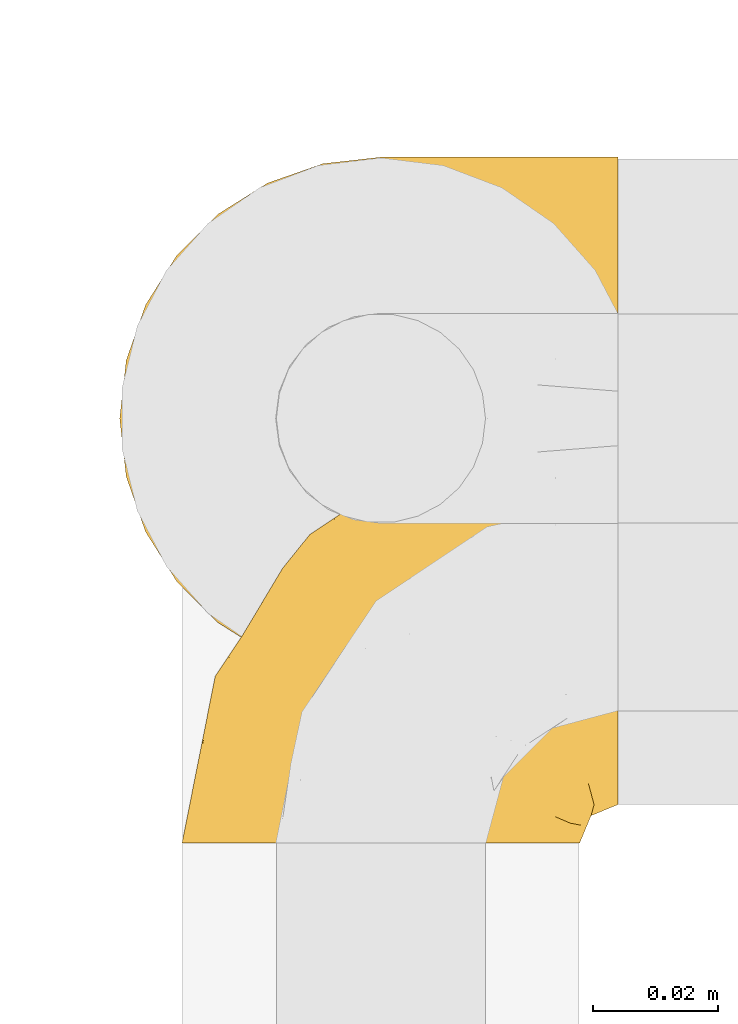
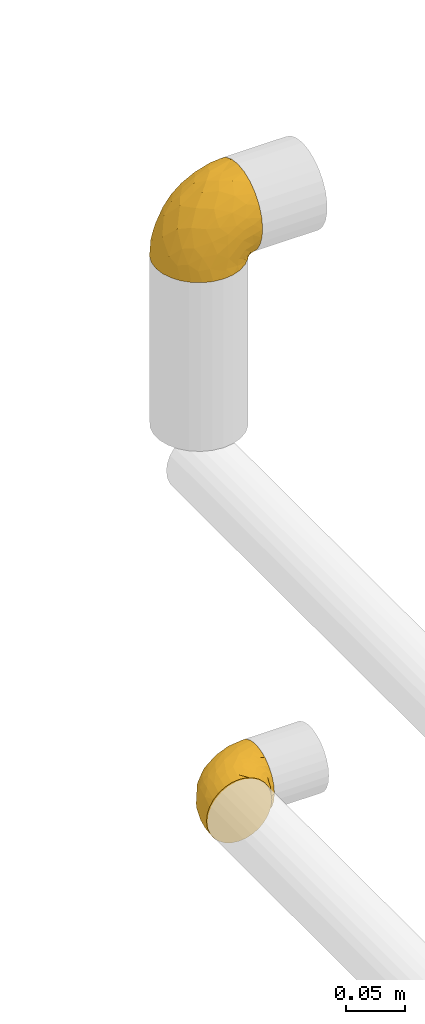
# One storey, part 22 of 39: 2 coverings.
"""IFC2X3 building model written with IfcOpenShell, lengths in millimetres."""

from ifc_helpers import new_model, entity, si_unit, converted_unit, derived_unit, direction, frame, origin, place, context, subcontext, project, spatial, faceted_brep, element, save


model = new_model("IFC2X3")

# Units and contexts
model_context = context("Model", 3, precision=0.01, world=origin(), true_north=direction((6.12303176911189e-17, 1.0)))
body_context = subcontext(model_context, "Body", "Model", "MODEL_VIEW")
ifc_project = project(units=[si_unit("LENGTHUNIT", "METRE", prefix="MILLI"), si_unit("AREAUNIT", "SQUARE_METRE"), si_unit("VOLUMEUNIT", "CUBIC_METRE"), converted_unit("PLANEANGLEUNIT", "DEGREE", entity("IfcRatioMeasure", 0.0174532925199433), si_unit("PLANEANGLEUNIT", "RADIAN"), dimensions=[0, 0, 0, 0, 0, 0, 0]), si_unit("MASSUNIT", "GRAM", prefix="KILO"), derived_unit("MASSDENSITYUNIT", [(si_unit("MASSUNIT", "GRAM", prefix="KILO"), 1), (si_unit("LENGTHUNIT", "METRE"), -3)]), derived_unit("MOMENTOFINERTIAUNIT", [(si_unit("LENGTHUNIT", "METRE"), 4)]), si_unit("TIMEUNIT", "SECOND"), si_unit("FREQUENCYUNIT", "HERTZ"), si_unit("THERMODYNAMICTEMPERATUREUNIT", "DEGREE_CELSIUS"), derived_unit("THERMALTRANSMITTANCEUNIT", [(si_unit("MASSUNIT", "GRAM", prefix="KILO"), 1), (si_unit("THERMODYNAMICTEMPERATUREUNIT", "KELVIN"), -1), (si_unit("TIMEUNIT", "SECOND"), -3)]), derived_unit("VOLUMETRICFLOWRATEUNIT", [(si_unit("LENGTHUNIT", "METRE"), 3), (si_unit("TIMEUNIT", "SECOND"), -1)]), derived_unit("MASSFLOWRATEUNIT", [(si_unit("MASSUNIT", "GRAM", prefix="KILO"), 1), (si_unit("TIMEUNIT", "SECOND"), -1)]), derived_unit("ROTATIONALFREQUENCYUNIT", [(si_unit("TIMEUNIT", "SECOND"), -1)]), si_unit("ELECTRICCURRENTUNIT", "AMPERE"), si_unit("ELECTRICVOLTAGEUNIT", "VOLT"), si_unit("POWERUNIT", "WATT"), si_unit("FORCEUNIT", "NEWTON", prefix="KILO"), si_unit("ILLUMINANCEUNIT", "LUX"), si_unit("LUMINOUSFLUXUNIT", "LUMEN"), si_unit("LUMINOUSINTENSITYUNIT", "CANDELA"), derived_unit("USERDEFINED", [(si_unit("MASSUNIT", "GRAM", prefix="KILO"), -1), (si_unit("LENGTHUNIT", "METRE"), -2), (si_unit("TIMEUNIT", "SECOND"), 3), (si_unit("LUMINOUSFLUXUNIT", "LUMEN"), 1)]), derived_unit("LINEARVELOCITYUNIT", [(si_unit("LENGTHUNIT", "METRE"), 1), (si_unit("TIMEUNIT", "SECOND"), -1)]), si_unit("PRESSUREUNIT", "PASCAL"), derived_unit("USERDEFINED", [(si_unit("LENGTHUNIT", "METRE"), -2), (si_unit("MASSUNIT", "GRAM", prefix="KILO"), 1), (si_unit("TIMEUNIT", "SECOND"), -2)]), derived_unit("LINEARFORCEUNIT", [(si_unit("MASSUNIT", "GRAM", prefix="KILO"), 1), (si_unit("LENGTHUNIT", "METRE"), 1), (si_unit("TIMEUNIT", "SECOND"), -2), (si_unit("LENGTHUNIT", "METRE"), -1)]), derived_unit("PLANARFORCEUNIT", [(si_unit("MASSUNIT", "GRAM", prefix="KILO"), 1), (si_unit("LENGTHUNIT", "METRE"), 1), (si_unit("TIMEUNIT", "SECOND"), -2), (si_unit("LENGTHUNIT", "METRE"), -2)])], contexts=[model_context])

# Site, building, storey
site_placement = place(None, origin())
site = spatial("IfcSite", under=ifc_project, at=site_placement, CompositionType="ELEMENT")
building_placement = place(site_placement, origin())
building = spatial("IfcBuilding", under=site, at=building_placement, CompositionType="ELEMENT")
storey_placement = place(building_placement, frame((0.0, 0.0, 24000.0)))
storey = spatial("IfcBuildingStorey", under=building, at=storey_placement, Name="07", CompositionType="ELEMENT", Elevation=24000.0)

# Coverings
covering_1_placement = place(storey_placement, frame((69571.57, 5253.91, 3610.4)))
element("IfcCovering", 1, at=covering_1_placement, inside=storey, Name=":ADSK_", ObjectType=":ADSK_", PredefinedType="INSULATION", context=body_context, shape_type="Brep", body=[
    faceted_brep([(25.28, 5.74, 1.6), (17.35, 10.73, 1.6), (10.72, 17.36, 1.6), (5.74, 25.29, 1.6), (2.64, 34.14, 1.6), (1.6, 43.45, 1.6), (2.65, 52.76, 1.6), (5.74, 61.61, 1.6), (10.73, 69.54, 1.6), (17.36, 76.17, 1.6), (25.29, 81.15, 1.6), (34.14, 84.25, 1.6), (43.45, 85.3, 1.6), (52.82, 84.23, 1.6), (61.71, 81.1, 1.6), (69.67, 76.06, 1.6), (76.31, 69.36, 1.6), (81.27, 61.36, 1.6), (81.27, 60.44, 1.6), (81.27, 59.52, 1.6), (81.27, 58.72, 1.6), (81.27, 57.4, 1.6), (81.27, 56.08, 1.6), (81.27, 54.76, 1.6), (81.27, 53.44, 1.6), (81.27, 52.12, 1.6), (81.27, 50.8, 1.6), (81.27, 49.47, 1.6), (81.27, 48.15, 1.6), (81.27, 46.83, 1.6), (81.27, 45.51, 1.6), (81.27, 44.19, 1.6), (81.27, 42.87, 1.6), (81.27, 41.55, 1.6), (81.27, 40.23, 1.6), (81.27, 39.31, 1.6), (81.27, 38.39, 1.6), (81.27, 37.48, 1.6), (81.27, 36.56, 1.6), (81.27, 35.64, 1.6), (81.27, 34.72, 1.6), (81.27, 33.8, 1.6), (81.27, 32.88, 1.6), (81.27, 31.96, 1.6), (81.27, 31.05, 1.6), (81.27, 30.13, 1.6), (81.27, 29.21, 1.6), (81.27, 28.29, 1.6), (81.27, 27.37, 1.6), (81.27, 26.45, 1.6), (81.27, 25.53, 1.6), (76.3, 17.52, 1.6), (69.66, 10.82, 1.6), (61.69, 5.78, 1.6), (52.8, 2.65, 1.6), (43.45, 1.6, 1.6), (34.13, 2.65, 1.6), (81.45, 69.37, 6.74), (81.45, 76.06, 13.37), (81.45, 81.1, 21.34), (81.45, 84.23, 30.23), (81.45, 85.3, 39.6), (81.45, 83.87, 50.43), (81.45, 79.69, 60.52), (81.45, 73.04, 69.19), (81.45, 64.37, 75.84), (81.45, 54.28, 80.02), (81.45, 43.45, 81.45), (81.45, 32.61, 80.02), (81.45, 22.52, 75.84), (81.45, 13.85, 69.19), (81.45, 7.2, 60.52), (81.45, 3.02, 50.43), (81.45, 1.6, 39.6), (81.45, 2.66, 30.23), (81.45, 5.79, 21.34), (81.45, 10.83, 13.37), (81.45, 17.52, 6.74), (81.45, 25.53, 1.77), (81.45, 26.45, 1.77), (81.45, 27.77, 1.77), (81.45, 28.89, 1.77), (81.45, 30.01, 1.77), (81.45, 31.13, 1.77), (81.45, 32.25, 1.77), (81.45, 33.37, 1.77), (81.45, 34.49, 1.77), (81.45, 35.61, 1.77), (81.45, 36.73, 1.77), (81.45, 37.85, 1.77), (81.45, 38.97, 1.77), (81.45, 40.09, 1.77), (81.45, 41.21, 1.77), (81.45, 42.33, 1.77), (81.45, 43.45, 1.77), (81.45, 44.77, 1.77), (81.45, 46.09, 1.77), (81.45, 47.41, 1.77), (81.45, 48.73, 1.77), (81.45, 50.05, 1.77), (81.45, 51.37, 1.77), (81.45, 52.69, 1.77), (81.45, 54.01, 1.77), (81.45, 54.93, 1.77), (81.45, 55.85, 1.77), (81.45, 56.76, 1.77), (81.45, 57.68, 1.77), (81.45, 58.6, 1.77), (81.45, 59.52, 1.77), (81.45, 60.44, 1.77), (81.45, 61.36, 1.77), (81.33, 32.81, 1.73), (81.32, 31.73, 1.72), (81.33, 50.71, 1.73), (81.32, 51.76, 1.72), (81.33, 42.89, 1.73), (81.32, 41.81, 1.73), (81.32, 25.53, 1.72), (81.32, 26.91, 1.72), (81.32, 40.71, 1.72), (81.32, 60.15, 1.72), (81.32, 39.53, 1.72), (81.32, 57.22, 1.73), (81.34, 58.17, 1.74), (81.32, 47.12, 1.72), (81.31, 33.93, 1.71), (81.33, 35.05, 1.73), (81.31, 46.09, 1.71), (81.32, 45.02, 1.72), (81.33, 43.95, 1.73), (81.32, 59.12, 1.72), (81.33, 38.49, 1.73), (81.32, 49.68, 1.72), (81.33, 53.35, 1.73), (81.32, 54.4, 1.72), (81.32, 56.2, 1.72), (81.32, 36.2, 1.72), (81.31, 37.29, 1.71), (81.32, 30.57, 1.72), (81.33, 29.45, 1.73), (81.31, 28.01, 1.71), (81.32, 61.36, 1.72), (81.3, 25.53, 1.68), (81.29, 25.53, 1.64), (81.29, 61.36, 1.64), (81.3, 61.36, 1.68), (81.4, 25.53, 1.75), (81.36, 61.36, 1.74), (81.4, 61.36, 1.75), (81.3, 55.3, 1.7), (81.33, 48.18, 1.73), (74.06, 82.92, 24.54), (45.99, 85.3, 11.1), (58.35, 82.92, 8.47), (67.76, 78.8, 9.11), (66.18, 78.8, 4.86), (76.46, 70.46, 5.0), (77.33, 71.16, 6.81), (71.95, 85.3, 37.05), (72.25, 76.1, 9.03), (78.91, 72.9, 9.47), (76.42, 78.81, 16.39), (73.52, 72.89, 3.95), (76.9, 74.06, 9.9), (65.25, 83.71, 22.7), (62.45, 85.3, 34.5), (74.31, 85.3, 37.68), (59.38, 83.61, 15.82), (48.54, 85.3, 20.6), (67.72, 80.61, 14.37), (55.49, 85.3, 27.55), (79.73, 67.83, 5.2), (73.23, 78.81, 14.88), (45.36, 85.3, 8.73), (15.81, 54.78, 44.27), (6.4, 57.27, 20.94), (7.67, 43.45, 32.15), (68.46, 84.45, 46.13), (59.33, 84.39, 42.67), (48.7, 77.16, 55.18), (53.94, 68.92, 67.27), (65.02, 76.65, 62.91), (60.77, 82.11, 51.5), (72.07, 82.11, 54.79), (26.25, 78.88, 25.78), (22.29, 78.88, 13.05), (16.0, 73.04, 18.46), (46.93, 84.47, 32.4), (14.19, 65.72, 31.07), (58.46, 51.16, 77.32), (61.51, 59.46, 75.62), (4.64, 43.45, 16.9), (68.93, 68.92, 71.69), (29.62, 51.18, 61.4), (24.85, 57.42, 54.47), (38.55, 83.48, 27.66), (31.27, 82.95, 14.53), (9.35, 65.72, 15.56), (37.15, 78.97, 42.26), (47.07, 82.64, 41.51), (26.49, 75.14, 36.93), (23.01, 68.58, 42.72), (19.4, 61.95, 44.68), (48.06, 58.11, 71.2), (42.46, 51.07, 70.48), (50.89, 43.45, 75.37), (35.78, 58.51, 63.65), (24.98, 43.45, 58.06), (16.33, 43.45, 45.11), (66.14, 43.45, 78.4), (30.96, 65.68, 54.95), (41.83, 70.41, 59.31), (33.28, 73.04, 49.01), (37.94, 43.45, 66.71), (67.39, 4.78, 53.75), (58.47, 35.48, 77.27), (32.5, 29.45, 61.6), (15.79, 32.11, 44.24), (15.99, 13.86, 18.46), (9.34, 21.19, 15.55), (56.91, 10.24, 60.14), (63.5, 17.97, 70.5), (44.08, 18.88, 63.0), (26.24, 8.01, 25.78), (22.27, 8.01, 13.05), (31.26, 3.95, 14.53), (23.95, 22.45, 48.5), (63.79, 2.4, 44.23), (62.45, 1.6, 34.5), (71.95, 1.6, 37.05), (45.36, 1.6, 8.73), (67.83, 29.05, 77.68), (70.28, 10.24, 64.08), (42.11, 35.7, 70.25), (6.39, 29.63, 20.93), (43.54, 8.75, 49.9), (58.03, 4.54, 49.6), (14.18, 21.19, 31.06), (56.34, 2.28, 39.62), (48.09, 2.53, 34.42), (48.54, 1.6, 20.6), (55.49, 1.6, 27.55), (21.78, 13.86, 33.36), (38.54, 3.41, 27.68), (45.99, 1.6, 11.1), (72.79, 2.35, 46.67), (33.26, 13.86, 49.0), (35.53, 7.35, 38.94), (53.66, 27.43, 73.05), (43.03, 13.39, 56.63), (49.68, 4.32, 43.85), (74.06, 3.97, 24.54), (59.37, 3.27, 15.82), (58.34, 3.97, 8.47), (67.75, 8.08, 9.12), (78.91, 13.99, 9.47), (76.9, 12.83, 9.91), (78.08, 8.08, 16.85), (73.23, 8.08, 14.88), (79.73, 19.06, 5.2), (77.34, 15.74, 6.81), (81.36, 25.53, 1.74), (73.51, 13.98, 3.96), (76.45, 16.42, 5.0), (66.41, 8.08, 5.86), (67.7, 6.27, 14.38), (72.24, 10.78, 9.04), (65.25, 3.18, 22.7)], [[[0, 1, 2, 3, 4, 5, 6, 7, 8, 9, 10, 11, 12, 13, 14, 15, 16, 17, 18, 19, 20, 21, 22, 23, 24, 25, 26, 27, 28, 29, 30, 31, 32, 33, 34, 35, 36, 37, 38, 39, 40, 41, 42, 43, 44, 45, 46, 47, 48, 49, 50, 51, 52, 53, 54, 55, 56]], [[57, 58, 59, 60, 61, 62, 63, 64, 65, 66, 67, 68, 69, 70, 71, 72, 73, 74, 75, 76, 77, 78, 79, 80, 81, 82, 83, 84, 85, 86, 87, 88, 89, 90, 91, 92, 93, 94, 95, 96, 97, 98, 99, 100, 101, 102, 103, 104, 105, 106, 107, 108, 109, 110]], [[111, 84, 112]], [[113, 26, 114]], [[114, 101, 100]], [[115, 93, 116]], [[79, 117, 118]], [[33, 116, 119]], [[117, 49, 118]], [[19, 18, 120]], [[119, 121, 34]], [[122, 21, 123]], [[97, 96, 124]], [[86, 125, 126]], [[116, 92, 119]], [[127, 96, 128]], [[32, 129, 115]], [[19, 120, 130]], [[121, 90, 131]], [[94, 115, 129]], [[115, 116, 32]], [[118, 49, 48]], [[113, 99, 132]], [[133, 114, 25]], [[24, 134, 133]], [[135, 22, 122]], [[136, 137, 88]], [[84, 83, 112]], [[138, 82, 139]], [[130, 20, 19]], [[118, 48, 140]], [[81, 140, 139]], [[123, 21, 20]], [[141, 120, 18]], [[139, 82, 81]], [[130, 107, 123]], [[49, 117, 142, 143, 50]], [[18, 17, 144, 145, 141]], [[79, 78, 146]], [[102, 133, 134]], [[105, 135, 122]], [[109, 141, 147, 148]], [[118, 80, 79]], [[80, 118, 140]], [[120, 109, 108]], [[47, 46, 140, 48]], [[81, 80, 140]], [[44, 112, 138]], [[93, 115, 94]], [[46, 139, 140]], [[46, 45, 139]], [[139, 45, 138]], [[138, 112, 83]], [[85, 84, 111]], [[112, 43, 111]], [[83, 82, 138]], [[106, 122, 123]], [[105, 122, 106]], [[21, 122, 22]], [[124, 29, 28]], [[33, 32, 116]], [[128, 129, 31]], [[32, 31, 129]], [[34, 33, 119]], [[116, 93, 92]], [[129, 95, 94]], [[95, 129, 128]], [[41, 40, 125, 42]], [[119, 91, 121]], [[36, 35, 131, 37]], [[137, 131, 89]], [[121, 131, 35]], [[90, 121, 91]], [[119, 92, 91]], [[136, 126, 39]], [[125, 86, 85]], [[42, 125, 111]], [[85, 111, 125]], [[149, 23, 22]], [[130, 108, 107]], [[130, 123, 20]], [[107, 106, 123]], [[137, 37, 131]], [[136, 38, 137]], [[89, 88, 137]], [[131, 90, 89]], [[124, 150, 97]], [[40, 39, 126]], [[87, 126, 136]], [[86, 126, 87]], [[136, 88, 87]], [[40, 126, 125]], [[39, 38, 136]], [[95, 128, 96]], [[30, 128, 31]], [[29, 124, 127]], [[127, 128, 30]], [[150, 124, 28]], [[127, 30, 29]], [[127, 124, 96]], [[150, 98, 97]], [[45, 44, 138]], [[26, 113, 132]], [[113, 100, 99]], [[132, 150, 27]], [[27, 26, 132]], [[26, 25, 114]], [[100, 113, 114]], [[101, 133, 102]], [[133, 101, 114]], [[28, 27, 150]], [[132, 99, 98]], [[23, 134, 24]], [[25, 24, 133]], [[134, 23, 149]], [[135, 104, 149]], [[149, 104, 103]], [[103, 102, 134]], [[130, 120, 108]], [[109, 120, 141]], [[42, 111, 43]], [[112, 44, 43]], [[104, 135, 105]], [[134, 149, 103]], [[135, 149, 22]], [[35, 34, 121]], [[137, 38, 37]], [[98, 150, 132]], [[59, 151, 60]], [[13, 152, 153]], [[154, 155, 153]], [[156, 157, 141]], [[158, 60, 151]], [[159, 156, 154]], [[160, 161, 58]], [[58, 161, 59]], [[144, 16, 162]], [[58, 57, 160]], [[161, 160, 163]], [[156, 162, 154]], [[162, 16, 15]], [[57, 148, 160]], [[151, 164, 165]], [[156, 144, 162]], [[60, 158, 166, 61]], [[155, 14, 153]], [[162, 155, 154]], [[154, 153, 167]], [[167, 153, 168]], [[154, 169, 159]], [[57, 110, 148]], [[144, 17, 16]], [[155, 15, 14]], [[170, 164, 167]], [[157, 163, 171]], [[14, 13, 153]], [[156, 141, 145, 144]], [[172, 163, 157]], [[172, 159, 169]], [[170, 165, 164]], [[167, 164, 169]], [[167, 168, 170]], [[151, 172, 164]], [[169, 154, 167]], [[164, 172, 169]], [[159, 172, 157]], [[171, 148, 147]], [[147, 141, 157]], [[157, 156, 159]], [[151, 165, 158]], [[172, 151, 161]], [[59, 161, 151]], [[13, 12, 173, 152]], [[152, 168, 153]], [[15, 155, 162]], [[161, 163, 172]], [[171, 163, 160]], [[148, 171, 160]], [[157, 171, 147]], [[174, 175, 176]], [[177, 165, 178]], [[179, 180, 181]], [[182, 183, 177]], [[184, 185, 186]], [[170, 187, 178]], [[173, 12, 11]], [[188, 175, 174]], [[189, 66, 190]], [[175, 6, 191]], [[192, 65, 64]], [[63, 183, 181]], [[63, 181, 64]], [[65, 192, 190]], [[183, 63, 62]], [[174, 193, 194]], [[195, 168, 196]], [[173, 11, 196]], [[8, 7, 197]], [[186, 9, 8]], [[196, 168, 152, 173]], [[196, 11, 10]], [[185, 196, 10]], [[198, 179, 199]], [[196, 184, 195]], [[200, 188, 201]], [[200, 186, 188]], [[194, 202, 174]], [[190, 203, 189]], [[175, 7, 6]], [[176, 175, 191]], [[188, 197, 175]], [[65, 190, 66]], [[197, 186, 8]], [[204, 205, 189]], [[9, 185, 10]], [[180, 206, 203]], [[207, 174, 176, 208]], [[66, 189, 209]], [[210, 211, 212]], [[189, 203, 204]], [[179, 181, 182]], [[192, 181, 180]], [[62, 61, 166]], [[195, 184, 198]], [[195, 199, 187]], [[6, 5, 191]], [[175, 197, 7]], [[186, 197, 188]], [[186, 185, 9]], [[196, 185, 184]], [[199, 179, 182]], [[179, 212, 211]], [[178, 182, 177]], [[184, 200, 198]], [[209, 189, 205]], [[209, 67, 66]], [[204, 203, 206]], [[193, 204, 206]], [[193, 213, 204]], [[194, 193, 206]], [[207, 193, 174]], [[206, 210, 194]], [[201, 202, 210]], [[211, 206, 180]], [[201, 210, 212]], [[200, 201, 212]], [[188, 174, 202]], [[198, 200, 212]], [[186, 200, 184]], [[179, 198, 212]], [[195, 198, 199]], [[210, 202, 194]], [[188, 202, 201]], [[206, 211, 210]], [[179, 211, 180]], [[213, 193, 207]], [[213, 205, 204]], [[195, 187, 168]], [[180, 203, 190]], [[181, 192, 64]], [[190, 192, 180]], [[177, 62, 166]], [[181, 183, 182]], [[62, 177, 183]], [[177, 166, 158, 165]], [[170, 178, 165]], [[199, 182, 178]], [[178, 187, 199]], [[168, 187, 170]], [[71, 214, 72]], [[205, 215, 209]], [[216, 207, 217]], [[215, 68, 209]], [[218, 219, 2]], [[220, 221, 222]], [[223, 224, 225]], [[226, 222, 216]], [[227, 228, 229]], [[56, 230, 225]], [[231, 221, 69]], [[56, 55, 230]], [[70, 232, 71]], [[71, 232, 214]], [[0, 56, 225]], [[207, 216, 233]], [[217, 176, 234]], [[220, 235, 236]], [[237, 219, 218]], [[1, 218, 2]], [[68, 215, 231]], [[234, 3, 219]], [[234, 191, 4]], [[1, 0, 224]], [[227, 238, 228]], [[239, 240, 241]], [[242, 237, 218]], [[223, 225, 243]], [[225, 240, 243]], [[3, 234, 4]], [[69, 221, 70]], [[224, 218, 1]], [[217, 234, 237]], [[242, 218, 223]], [[217, 226, 216]], [[3, 2, 219]], [[217, 207, 208, 176]], [[225, 230, 244, 240]], [[214, 227, 245]], [[246, 247, 235]], [[247, 223, 243]], [[222, 221, 248]], [[232, 221, 220]], [[241, 238, 239]], [[247, 246, 242]], [[216, 222, 248]], [[249, 246, 235]], [[215, 233, 248]], [[217, 237, 226]], [[191, 234, 176]], [[191, 5, 4]], [[72, 245, 73]], [[234, 219, 237]], [[225, 224, 0]], [[218, 224, 223]], [[239, 247, 243]], [[238, 241, 228]], [[235, 247, 250]], [[68, 67, 209]], [[233, 215, 205]], [[215, 248, 231]], [[233, 205, 213, 207]], [[248, 233, 216]], [[221, 231, 248]], [[69, 68, 231]], [[245, 227, 229]], [[236, 227, 214]], [[242, 226, 237]], [[222, 226, 246]], [[73, 245, 229]], [[214, 245, 72]], [[247, 242, 223]], [[226, 242, 246]], [[236, 235, 250]], [[249, 220, 222]], [[221, 232, 70]], [[214, 232, 220]], [[220, 236, 214]], [[238, 236, 250]], [[236, 238, 227]], [[238, 250, 239]], [[247, 239, 250]], [[240, 239, 243]], [[220, 249, 235]], [[222, 246, 249]], [[74, 229, 251]], [[252, 253, 254]], [[146, 77, 255]], [[256, 257, 258]], [[259, 255, 256]], [[259, 260, 261]], [[75, 74, 251]], [[51, 143, 262]], [[263, 143, 142, 117]], [[255, 77, 76]], [[251, 257, 75]], [[252, 240, 253]], [[253, 244, 54]], [[257, 255, 76]], [[53, 52, 264]], [[254, 265, 252]], [[253, 264, 254]], [[254, 264, 262]], [[75, 257, 76]], [[265, 254, 266]], [[254, 262, 263]], [[51, 50, 143]], [[54, 244, 230, 55]], [[51, 262, 52]], [[252, 267, 241]], [[253, 54, 53]], [[266, 258, 265]], [[146, 78, 77]], [[263, 117, 260]], [[146, 255, 259]], [[256, 258, 260]], [[267, 252, 265]], [[228, 267, 251]], [[241, 267, 228]], [[241, 240, 252]], [[251, 267, 258]], [[254, 263, 266]], [[258, 267, 265]], [[260, 117, 261]], [[263, 260, 266]], [[258, 266, 260]], [[229, 74, 73]], [[229, 228, 251]], [[258, 257, 251]], [[253, 240, 244]], [[53, 264, 253]], [[52, 262, 264]], [[143, 263, 262]], [[257, 256, 255]], [[260, 259, 256]], [[146, 259, 261]], [[79, 146, 261]], [[79, 261, 117]], [[109, 148, 110]]]),
])
covering_2_placement = place(storey_placement, frame((69581.57, 5227.76, 3046.55)))
element("IfcCovering", 2, at=covering_2_placement, inside=storey, Name=":ADSK_", ObjectType=":ADSK_", PredefinedType="INSULATION", context=body_context, shape_type="Brep", body=[
    faceted_brep([(2.39, 1.6, 40.53), (1.6, 1.6, 33.45), (2.39, 1.6, 26.35), (4.75, 1.6, 19.62), (8.55, 1.6, 13.58), (13.59, 1.6, 8.54), (19.63, 1.6, 4.75), (26.36, 1.6, 2.39), (33.45, 1.6, 1.6), (37.35, 1.6, 2.04), (40.54, 1.6, 2.39), (43.9, 1.6, 3.57), (47.27, 1.6, 4.75), (53.31, 1.6, 8.55), (58.35, 1.6, 13.59), (62.14, 1.6, 19.63), (64.5, 1.6, 26.36), (65.3, 1.6, 33.45), (64.5, 1.6, 40.54), (62.14, 1.6, 47.27), (58.34, 1.6, 53.31), (53.3, 1.6, 58.35), (47.26, 1.6, 62.14), (43.89, 1.6, 63.32), (40.53, 1.6, 64.5), (37.35, 1.6, 64.86), (35.4, 1.6, 65.08), (33.45, 1.6, 65.3), (26.35, 1.6, 64.5), (19.62, 1.6, 62.14), (13.58, 1.6, 58.34), (8.54, 1.6, 53.3), (4.75, 1.6, 47.26), (71.45, 23.67, 5.86), (71.45, 27.51, 4.27), (71.45, 31.35, 2.68), (71.45, 35.67, 2.11), (71.45, 37.63, 1.85), (71.45, 39.6, 1.6), (71.45, 47.84, 2.68), (71.45, 55.52, 5.86), (71.45, 62.12, 10.92), (71.45, 67.18, 17.52), (71.45, 70.36, 25.2), (71.45, 71.45, 33.45), (71.45, 70.36, 41.69), (71.45, 67.18, 49.37), (71.45, 62.12, 55.97), (71.45, 55.52, 61.03), (71.45, 47.84, 64.21), (71.45, 39.6, 65.3), (71.45, 35.67, 64.78), (71.45, 31.35, 64.21), (71.45, 27.51, 62.62), (71.45, 23.67, 61.03), (71.45, 20.37, 58.5), (71.45, 17.07, 55.97), (71.45, 12.01, 49.37), (71.45, 8.83, 41.69), (71.45, 7.75, 33.45), (71.45, 8.83, 25.2), (71.45, 12.01, 17.52), (71.45, 17.07, 10.92), (71.45, 20.37, 8.39), (37.48, 33.94, 64.03), (38.54, 20.6, 65.3), (42.01, 24.07, 65.3), (45.49, 27.55, 65.3), (48.97, 31.03, 65.3), (52.45, 34.5, 65.3), (58.08, 68.79, 33.45), (40.84, 53.62, 56.13), (47.91, 50.17, 61.0), (55.67, 58.62, 57.25), (55.18, 67.51, 44.44), (45.13, 61.03, 50.33), (59.19, 64.5, 51.72), (11.67, 17.98, 54.4), (38.17, 61.71, 41.87), (28.82, 52.25, 48.25), (29.48, 16.72, 64.6), (32.11, 39.09, 60.78), (24.68, 25.86, 61.71), (55.82, 44.07, 64.46), (28.37, 44.36, 55.78), (9.18, 31.35, 40.71), (4.95, 17.72, 42.87), (11.17, 29.45, 47.87), (60.89, 52.37, 62.12), (55.35, 35.28, 65.3), (58.25, 36.06, 65.3), (61.15, 36.84, 65.3), (64.05, 37.61, 65.3), (65.9, 38.11, 65.3), (67.75, 38.61, 65.3), (16.27, 14.07, 59.32), (6.97, 13.65, 49.35), (4.25, 14.96, 33.45), (21.84, 13.32, 62.53), (33.94, 3.44, 65.3), (34.44, 5.29, 65.3), (35.43, 8.99, 65.3), (36.2, 11.89, 65.3), (36.98, 14.79, 65.3), (37.76, 17.69, 65.3), (18.84, 29.19, 57.03), (14.39, 28.91, 52.84), (51.68, 68.17, 38.52), (6.91, 28.33, 33.45), (26.05, 53.45, 41.09), (33.38, 58.56, 33.45), (22.05, 50.99, 33.45), (17.7, 43.14, 44.35), (19.21, 39.23, 51.29), (44.71, 66.13, 33.45), (17.7, 45.6, 38.44), (14.48, 39.66, 33.45), (66.98, 18.04, 57.42), (65.01, 22.76, 61.06), (61.98, 21.95, 61.24), (64.85, 32.18, 64.58), (62.15, 29.08, 64.0), (48.67, 20.77, 64.21), (63.81, 4.75, 44.85), (50.71, 11.03, 61.42), (48.45, 6.78, 61.84), (52.85, 5.68, 59.03), (67.6, 7.71, 41.64), (65.48, 4.42, 38.8), (67.1, 5.94, 33.45), (66.68, 14.52, 54.12), (43.2, 11.63, 64.27), (44.92, 6.6, 63.33), (58.1, 7.33, 54.97), (61.92, 12.48, 54.91), (63.17, 7.99, 49.44), (66.68, 11.14, 49.79), (56.7, 14.07, 59.23), (50.86, 15.37, 62.42), (54.42, 10.81, 59.27), (40.7, 7.89, 64.6), (57.76, 26.18, 63.73), (61.34, 5.8, 50.25), (59.9, 9.94, 54.66), (58.0, 22.23, 62.35), (62.43, 18.39, 59.05), (45.83, 17.71, 64.34), (58.99, 16.87, 59.52), (45.9, 13.24, 63.71), (67.3, 24.95, 61.92), (53.12, 26.59, 64.52), (49.43, 26.16, 64.9), (53.9, 22.11, 63.33), (52.92, 17.43, 62.23), (63.81, 4.75, 22.04), (61.35, 5.8, 16.65), (63.17, 7.99, 17.46), (56.72, 14.07, 7.66), (59.87, 10.06, 12.13), (54.39, 11.54, 7.35), (67.59, 7.71, 25.25), (40.71, 7.89, 2.29), (35.43, 8.99, 1.6), (36.2, 11.89, 1.6), (36.98, 14.79, 1.6), (65.48, 4.42, 28.1), (58.19, 22.42, 4.51), (55.78, 27.95, 2.45), (62.46, 22.22, 5.62), (69.6, 39.1, 1.6), (61.15, 36.84, 1.6), (64.05, 37.61, 1.6), (67.75, 38.61, 1.6), (67.39, 21.49, 6.96), (66.16, 26.52, 4.16), (58.11, 18.09, 6.38), (62.44, 18.39, 7.84), (61.95, 13.88, 10.87), (66.68, 11.14, 17.1), (64.85, 32.18, 2.31), (52.45, 34.5, 1.6), (48.97, 31.03, 1.6), (43.18, 11.65, 2.62), (52.88, 5.67, 7.88), (48.46, 6.81, 5.05), (34.44, 5.29, 1.6), (34.93, 7.14, 1.6), (58.11, 7.34, 11.92), (58.25, 36.06, 1.6), (60.72, 31.38, 2.23), (49.13, 19.83, 2.95), (45.49, 27.55, 1.6), (53.71, 22.94, 3.29), (44.93, 6.6, 3.56), (67.04, 17.93, 9.57), (66.6, 14.52, 12.74), (44.91, 17.45, 2.39), (50.72, 11.03, 5.47), (37.76, 17.69, 1.6), (38.54, 20.6, 1.6), (46.39, 12.33, 3.46), (57.7, 30.27, 2.2), (55.35, 35.28, 1.6), (62.73, 25.9, 4.02), (42.01, 24.07, 1.6), (55.67, 58.62, 9.64), (21.85, 13.32, 4.35), (29.49, 16.72, 2.29), (55.82, 44.07, 2.43), (38.17, 61.71, 25.02), (55.18, 67.51, 22.45), (45.12, 61.03, 16.56), (47.92, 50.18, 5.89), (37.47, 33.92, 2.86), (32.11, 39.08, 6.1), (40.85, 53.62, 10.76), (51.68, 68.17, 28.37), (60.89, 52.37, 4.77), (59.19, 64.5, 15.17), (24.69, 25.86, 5.18), (16.28, 14.07, 7.56), (18.85, 29.18, 9.85), (11.19, 29.46, 19.01), (4.95, 17.73, 24.01), (9.19, 31.37, 26.18), (11.68, 17.99, 12.48), (26.05, 53.45, 25.8), (19.23, 39.25, 15.6), (14.4, 28.92, 14.04), (6.97, 13.65, 17.53), (28.8, 52.23, 18.64), (17.7, 43.13, 22.54), (28.37, 44.36, 11.1), (17.7, 45.6, 28.45)], [[[0, 1, 2, 3, 4, 5, 6, 7, 8, 9, 10, 11, 12, 13, 14, 15, 16, 17, 18, 19, 20, 21, 22, 23, 24, 25, 26, 27, 28, 29, 30, 31, 32]], [[33, 34, 35, 36, 37, 38, 39, 40, 41, 42, 43, 44, 45, 46, 47, 48, 49, 50, 51, 52, 53, 54, 55, 56, 57, 58, 59, 60, 61, 62, 63]], [[64, 65, 66, 67, 68, 69]], [[45, 44, 70]], [[71, 72, 73]], [[74, 75, 76]], [[77, 31, 30]], [[75, 78, 79]], [[27, 80, 28]], [[74, 46, 45]], [[64, 81, 82]], [[46, 76, 47]], [[83, 50, 49]], [[48, 47, 73]], [[71, 79, 84]], [[85, 86, 87]], [[49, 48, 88]], [[83, 69, 89, 90, 91, 92, 93, 94, 50]], [[95, 77, 30]], [[75, 74, 78]], [[87, 86, 96]], [[96, 86, 32]], [[96, 32, 31]], [[0, 86, 97]], [[83, 64, 69]], [[98, 80, 82]], [[73, 72, 88]], [[64, 80, 65]], [[1, 0, 97]], [[80, 27, 99, 100, 101, 102, 103, 104, 65]], [[77, 105, 106]], [[64, 82, 80]], [[70, 107, 45]], [[77, 95, 105]], [[82, 95, 98]], [[95, 30, 29]], [[74, 107, 78]], [[86, 0, 32]], [[72, 71, 81]], [[85, 108, 86]], [[76, 73, 47]], [[71, 84, 81]], [[109, 110, 111]], [[87, 112, 85]], [[79, 109, 112]], [[79, 112, 113]], [[88, 83, 49]], [[64, 83, 72]], [[31, 77, 96]], [[87, 96, 77]], [[98, 95, 29]], [[105, 95, 82]], [[81, 105, 82]], [[105, 84, 113]], [[29, 28, 98]], [[114, 107, 70]], [[80, 98, 28]], [[73, 75, 71]], [[79, 71, 75]], [[74, 76, 46]], [[73, 76, 75]], [[78, 107, 114]], [[45, 107, 74]], [[87, 113, 112]], [[115, 85, 112]], [[109, 79, 78]], [[113, 87, 106]], [[116, 115, 111]], [[116, 108, 85]], [[79, 113, 84]], [[109, 78, 110]], [[115, 109, 111]], [[85, 115, 116]], [[109, 115, 112]], [[72, 81, 64]], [[105, 81, 84]], [[73, 88, 48]], [[83, 88, 72]], [[86, 108, 97]], [[78, 114, 110]], [[113, 106, 105]], [[87, 77, 106]], [[117, 118, 119]], [[52, 120, 54, 53]], [[91, 120, 52]], [[91, 90, 120]], [[90, 121, 120]], [[122, 67, 66]], [[18, 123, 19]], [[124, 125, 126]], [[127, 59, 58]], [[128, 129, 127]], [[130, 57, 117]], [[131, 132, 125]], [[19, 133, 20]], [[128, 18, 17]], [[134, 135, 136]], [[137, 138, 139]], [[131, 103, 140]], [[22, 140, 23]], [[131, 65, 104, 103]], [[99, 27, 26, 25, 24, 101, 100]], [[141, 118, 121]], [[19, 123, 142]], [[52, 51, 50, 94, 93, 92, 91]], [[129, 128, 17]], [[117, 56, 118]], [[135, 134, 143]], [[139, 126, 133]], [[119, 144, 145]], [[127, 135, 123]], [[136, 58, 57]], [[101, 24, 23]], [[124, 138, 146]], [[140, 101, 23]], [[145, 147, 134]], [[140, 132, 131]], [[140, 103, 102, 101]], [[140, 22, 132]], [[146, 148, 124]], [[121, 69, 141]], [[55, 149, 118]], [[150, 151, 152]], [[147, 137, 134]], [[144, 150, 152]], [[152, 151, 122]], [[138, 122, 146]], [[59, 127, 129]], [[123, 18, 128]], [[58, 136, 127]], [[135, 127, 136]], [[121, 90, 89, 69]], [[120, 121, 149]], [[122, 66, 146]], [[153, 122, 138]], [[141, 69, 68]], [[127, 123, 128]], [[123, 135, 142]], [[143, 142, 135]], [[19, 142, 133]], [[66, 65, 146]], [[148, 65, 131]], [[22, 21, 132]], [[125, 132, 21]], [[126, 125, 21]], [[148, 125, 124]], [[21, 20, 126]], [[133, 126, 20]], [[139, 138, 124]], [[153, 138, 137]], [[126, 139, 124]], [[139, 133, 143]], [[147, 153, 137]], [[152, 122, 153]], [[134, 136, 130]], [[137, 139, 143]], [[144, 147, 145]], [[153, 147, 152]], [[65, 148, 146]], [[125, 148, 131]], [[141, 144, 119]], [[55, 54, 149]], [[137, 143, 134]], [[142, 143, 133]], [[130, 117, 145]], [[57, 56, 117]], [[134, 130, 145]], [[57, 130, 136]], [[150, 144, 141]], [[147, 144, 152]], [[141, 68, 150]], [[151, 68, 67]], [[117, 119, 145]], [[141, 119, 118]], [[68, 151, 150]], [[122, 151, 67]], [[118, 56, 55]], [[120, 149, 54]], [[118, 149, 121]], [[154, 155, 156]], [[157, 158, 159]], [[129, 160, 59]], [[161, 162, 163, 164]], [[165, 160, 129]], [[166, 167, 168]], [[169, 38, 37, 36, 35, 170, 171, 172]], [[63, 173, 174]], [[175, 176, 177]], [[60, 178, 61]], [[179, 35, 34, 33]], [[160, 60, 59]], [[180, 167, 181]], [[129, 17, 165]], [[182, 161, 164]], [[183, 13, 184]], [[9, 8, 185, 186, 162, 10]], [[187, 155, 15]], [[188, 179, 189]], [[187, 15, 14]], [[190, 191, 192]], [[182, 193, 161]], [[194, 176, 168]], [[176, 195, 177]], [[196, 190, 197]], [[11, 10, 162]], [[11, 161, 12]], [[187, 14, 183]], [[12, 161, 193]], [[156, 158, 177]], [[165, 17, 16]], [[194, 195, 176]], [[187, 159, 158]], [[179, 174, 189]], [[182, 164, 198, 199]], [[200, 199, 196]], [[193, 184, 13]], [[194, 168, 173]], [[201, 202, 189]], [[16, 154, 165]], [[160, 156, 178]], [[160, 165, 154]], [[178, 60, 160]], [[170, 35, 179]], [[188, 170, 179]], [[189, 174, 203]], [[174, 179, 33]], [[201, 189, 203]], [[181, 192, 191]], [[167, 180, 201]], [[192, 175, 190]], [[159, 190, 157]], [[15, 154, 16]], [[204, 196, 199]], [[204, 191, 190]], [[160, 154, 156]], [[15, 155, 154]], [[158, 155, 187]], [[203, 173, 168]], [[192, 181, 167]], [[190, 196, 204]], [[200, 196, 197]], [[184, 193, 182]], [[13, 12, 193]], [[200, 184, 182]], [[184, 200, 183]], [[187, 183, 197]], [[14, 13, 183]], [[162, 161, 11]], [[63, 62, 173]], [[174, 33, 63]], [[173, 62, 194]], [[174, 173, 203]], [[62, 61, 194]], [[195, 61, 178]], [[61, 195, 194]], [[177, 195, 178]], [[156, 177, 178]], [[175, 192, 166]], [[166, 168, 176]], [[167, 203, 168]], [[175, 166, 176]], [[167, 166, 192]], [[177, 157, 175]], [[190, 175, 157]], [[187, 197, 159]], [[190, 159, 197]], [[177, 158, 157]], [[155, 158, 156]], [[167, 201, 203]], [[200, 197, 183]], [[202, 201, 180]], [[202, 188, 189]], [[199, 200, 182]], [[41, 40, 205]], [[206, 207, 7]], [[208, 38, 169, 172, 171, 170, 188, 202, 180]], [[209, 210, 211]], [[212, 213, 214]], [[212, 215, 205]], [[43, 210, 216]], [[217, 40, 39]], [[216, 114, 70]], [[208, 213, 212]], [[205, 40, 217]], [[218, 42, 41]], [[216, 209, 114]], [[42, 218, 210]], [[214, 213, 219]], [[219, 220, 221]], [[199, 207, 213]], [[213, 207, 219]], [[8, 7, 207]], [[222, 223, 224]], [[4, 225, 5]], [[2, 97, 223]], [[110, 226, 111]], [[225, 220, 5]], [[227, 221, 228]], [[223, 229, 3]], [[2, 223, 3]], [[230, 231, 226]], [[224, 223, 108]], [[42, 210, 43]], [[230, 209, 211]], [[222, 225, 229]], [[38, 208, 39]], [[3, 229, 4]], [[213, 180, 181, 191, 204, 199]], [[220, 206, 6]], [[5, 220, 6]], [[207, 199, 198, 164, 163, 162, 186, 185, 8]], [[212, 214, 215]], [[218, 205, 211]], [[211, 215, 230]], [[226, 110, 209]], [[222, 231, 227]], [[222, 224, 231]], [[213, 208, 180]], [[217, 208, 212]], [[222, 229, 223]], [[225, 4, 229]], [[221, 220, 225]], [[206, 220, 219]], [[228, 221, 225]], [[214, 221, 232]], [[207, 206, 219]], [[44, 43, 70]], [[7, 6, 206]], [[230, 215, 232]], [[211, 205, 215]], [[205, 218, 41]], [[210, 218, 211]], [[43, 216, 70]], [[209, 216, 210]], [[233, 116, 111]], [[230, 232, 227]], [[224, 116, 233]], [[230, 226, 209]], [[224, 108, 116]], [[230, 227, 231]], [[221, 227, 232]], [[233, 226, 231]], [[225, 222, 228]], [[226, 233, 111]], [[224, 233, 231]], [[221, 214, 219]], [[214, 232, 215]], [[208, 217, 39]], [[205, 217, 212]], [[97, 2, 1]], [[97, 108, 223]], [[110, 114, 209]], [[227, 228, 222]]]),
])

save(model, "model.ifc")
